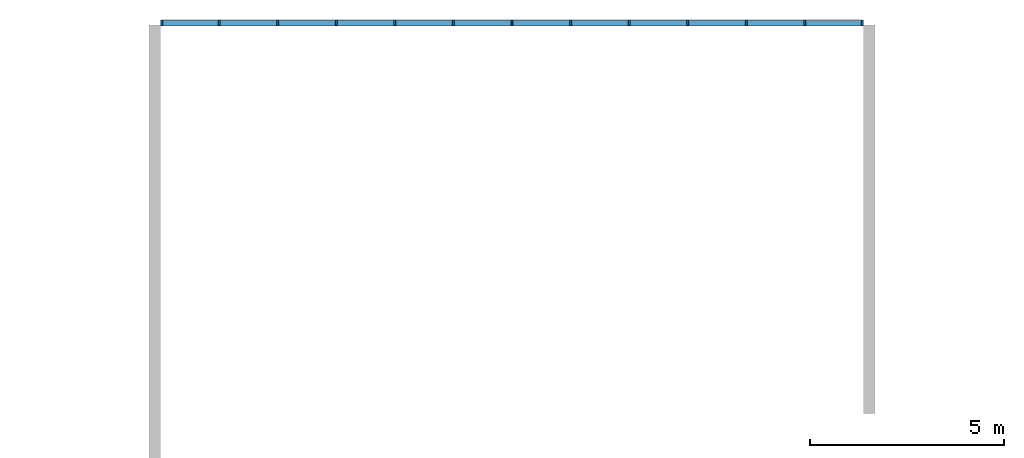
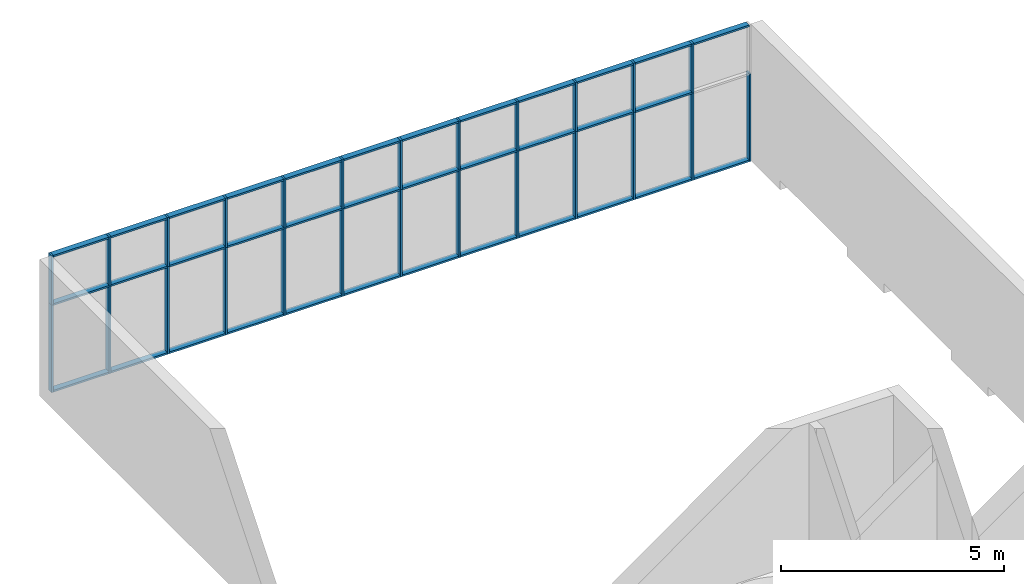
# One storey, part 4 of 13: 60 members, 1 element without a shape of its own.
"""IFC2X3 building model written with IfcOpenShell, lengths in millimetres."""

from ifc_helpers import new_model, entity, si_unit, converted_unit, derived_unit, direction, frame, frame_2d, origin, origin_2d_with_axis, place, context, subcontext, project, spatial, rectangle, extrude, material, type_object, element, aggregate, save


model = new_model("IFC2X3")

# Units and contexts
model_context = context("Model", 3, precision=0.01, world=origin(), true_north=direction((6.12303176911189e-17, 1.0)))
context_of_model = context(None, 3, precision=0.01, world=origin(), true_north=direction((6.12303176911189e-17, 1.0)))
body_context = subcontext(model_context, "Body", "Model", "MODEL_VIEW")
ifc_project = project(units=[si_unit("LENGTHUNIT", "METRE", prefix="MILLI"), si_unit("AREAUNIT", "SQUARE_METRE"), si_unit("VOLUMEUNIT", "CUBIC_METRE"), converted_unit("PLANEANGLEUNIT", "DEGREE", entity("IfcRatioMeasure", 0.0174532925199433), si_unit("PLANEANGLEUNIT", "RADIAN"), dimensions=[0, 0, 0, 0, 0, 0, 0]), si_unit("MASSUNIT", "GRAM", prefix="KILO"), si_unit("TIMEUNIT", "SECOND"), si_unit("FREQUENCYUNIT", "HERTZ"), si_unit("THERMODYNAMICTEMPERATUREUNIT", "DEGREE_CELSIUS"), derived_unit("THERMALTRANSMITTANCEUNIT", [(si_unit("MASSUNIT", "GRAM", prefix="KILO"), 1), (si_unit("THERMODYNAMICTEMPERATUREUNIT", "KELVIN"), -1), (si_unit("TIMEUNIT", "SECOND"), -3)]), derived_unit("VOLUMETRICFLOWRATEUNIT", [(si_unit("LENGTHUNIT", "METRE"), 3), (si_unit("TIMEUNIT", "SECOND"), -1)]), si_unit("ELECTRICCURRENTUNIT", "AMPERE"), si_unit("ELECTRICVOLTAGEUNIT", "VOLT"), si_unit("POWERUNIT", "WATT"), si_unit("FORCEUNIT", "NEWTON", prefix="KILO"), si_unit("ILLUMINANCEUNIT", "LUX"), si_unit("LUMINOUSFLUXUNIT", "LUMEN"), si_unit("LUMINOUSINTENSITYUNIT", "CANDELA"), si_unit("PRESSUREUNIT", "PASCAL")], contexts=[model_context, context_of_model])

# Site, building, storey
site_placement = place(None, origin())
site = spatial("IfcSite", under=ifc_project, at=site_placement, CompositionType="ELEMENT")
building_placement = place(site_placement, origin())
building = spatial("IfcBuilding", under=site, at=building_placement, CompositionType="ELEMENT")
storey_placement = place(building_placement, frame((0.0, 0.0, 3750.0)))
storey = spatial("IfcBuildingStorey", under=building, at=storey_placement, Name="02. 2 etg.", CompositionType="ELEMENT", Elevation=3750.00000000068)

# Curtain wall, members
curtain_wall_type = type_object("IfcCurtainWallType", Name="Curtain Wall:Storefront", PredefinedType="NOTDEFINED")
curtain_wall_placement = place(storey_placement, frame((0.0, 0.0, -3750.0)))
curtain_wall = element("IfcCurtainWall", 1, at=curtain_wall_placement, inside=storey, type_object=curtain_wall_type, Name="Curtain Wall:Storefront", ObjectType="Curtain Wall:Storefront")
ifc_material = material(Name="Aluminium")
member_1_placement = place(curtain_wall_placement, frame((28012.4511895081, 18905.0, 7450.0)))
member_1 = element("IfcMember", 2, at=member_1_placement, material=ifc_material, Name="Curtain Wall:Storefront:8486", ObjectType="Curtain Wall:Storefront:8486", context=body_context, shape_type="SweptSolid", body=[
    extrude(rectangle(XDim=1436.66666666667, YDim=150.000000000001, at=frame_2d((0.0, 1.08713038571295e-12), x_axis=(1.0, 0.0))), frame((718.333333333335, 75.0, 0.0), z_axis=(0.0, 0.0, 1.0), x_axis=(-1.0, 0.0, 0.0)), (0.0, 0.0, 1.0), 49.9999999999995),
])
member_2_placement = place(curtain_wall_placement, frame((11409.1178561748, 18905.0, 3750.0)))
member_2 = element("IfcMember", 3, at=member_2_placement, material=ifc_material, Name="Curtain Wall:Storefront:8486", ObjectType="Curtain Wall:Storefront:8486", context=body_context, shape_type="SweptSolid", body=[
    extrude(rectangle(XDim=1436.66666666667, YDim=150.000000000001, at=frame_2d((1.08002495835535e-12, 1.08713038571295e-12), x_axis=(1.0, 0.0))), frame((718.333333333335, 75.0, 0.0)), (0.0, 0.0, 1.0), 50.0),
])
member_3_placement = place(curtain_wall_placement, frame((29449.1178561748, 18905.0, 3750.0)))
member_3 = element("IfcMember", 4, at=member_3_placement, material=ifc_material, Name="Curtain Wall:Storefront:8486", ObjectType="Curtain Wall:Storefront:8486", context=body_context, shape_type="SweptSolid", body=[
    extrude(rectangle(XDim=149.999999999998, YDim=50.0000000000016, at=frame_2d((-1.08002495835535e-12, -2.16715534406831e-12), x_axis=(1.0, 0.0))), frame((25.0, 75.0, 0.0), z_axis=(0.0, 0.0, 1.0), x_axis=(0.0, 1.0, 0.0)), (0.0, 0.0, 1.0), 2400.0),
])
member_4_placement = place(curtain_wall_placement, frame((11359.1178561748, 18905.0, 6150.0)))
member_4 = element("IfcMember", 5, at=member_4_placement, material=ifc_material, Name="Curtain Wall:Storefront:8486", ObjectType="Curtain Wall:Storefront:8486", context=body_context, shape_type="SweptSolid", body=[
    extrude(rectangle(XDim=49.9999999999995, YDim=149.999999999998, at=frame_2d((2.16715534406831e-12, 1.08002495835535e-12), x_axis=(1.0, 0.0))), frame((25.0, 75.0, 0.0)), (0.0, 0.0, 1.0), 1349.99999999993),
])
member_5_placement = place(curtain_wall_placement, frame((11409.1178561748, 18905.0, 7450.0)))
member_5 = element("IfcMember", 6, at=member_5_placement, material=ifc_material, Name="Curtain Wall:Storefront:8486", ObjectType="Curtain Wall:Storefront:8486", context=body_context, shape_type="SweptSolid", body=[
    extrude(rectangle(XDim=1436.66666666667, YDim=150.000000000001, at=frame_2d((-1.08002495835535e-12, 1.08713038571295e-12), x_axis=(1.0, 0.0))), frame((718.333333333335, 75.0, 0.0), z_axis=(0.0, 0.0, 1.0), x_axis=(-1.0, 0.0, 0.0)), (0.0, 0.0, 1.0), 49.9999999999995),
])
member_6_placement = place(curtain_wall_placement, frame((12895.7845228414, 18905.0, 7450.0)))
member_6 = element("IfcMember", 7, at=member_6_placement, material=ifc_material, Name="Curtain Wall:Storefront:8486", ObjectType="Curtain Wall:Storefront:8486", context=body_context, shape_type="SweptSolid", body=[
    extrude(rectangle(XDim=1461.66666666667, YDim=150.000000000001, at=frame_2d((1.08002495835535e-12, 0.0), x_axis=(1.0, 0.0))), frame((730.833333333334, 75.0, 0.0), z_axis=(0.0, 0.0, 1.0), x_axis=(-1.0, 0.0, 0.0)), (0.0, 0.0, 1.0), 49.9999999999995),
])
member_7_placement = place(curtain_wall_placement, frame((14407.4511895081, 18905.0, 7450.0)))
member_7 = element("IfcMember", 8, at=member_7_placement, material=ifc_material, Name="Curtain Wall:Storefront:8486", ObjectType="Curtain Wall:Storefront:8486", context=body_context, shape_type="SweptSolid", body=[
    extrude(rectangle(XDim=1461.66666666667, YDim=150.000000000001, at=frame_2d((-1.08002495835535e-12, 0.0), x_axis=(1.0, 0.0))), frame((730.833333333332, 75.0, 0.0), z_axis=(0.0, 0.0, 1.0), x_axis=(-1.0, 0.0, 0.0)), (0.0, 0.0, 1.0), 49.9999999999995),
])
member_8_placement = place(curtain_wall_placement, frame((15919.1178561748, 18905.0, 7450.0)))
member_8 = element("IfcMember", 9, at=member_8_placement, material=ifc_material, Name="Curtain Wall:Storefront:8486", ObjectType="Curtain Wall:Storefront:8486", context=body_context, shape_type="SweptSolid", body=[
    extrude(rectangle(XDim=1461.66666666667, YDim=150.000000000001, at=frame_2d((-1.08002495835535e-12, 0.0), x_axis=(1.0, 0.0))), frame((730.833333333332, 75.0, 0.0), z_axis=(0.0, 0.0, 1.0), x_axis=(-1.0, 0.0, 0.0)), (0.0, 0.0, 1.0), 49.9999999999995),
])
member_9_placement = place(curtain_wall_placement, frame((17430.7845228414, 18905.0, 7450.0)))
member_9 = element("IfcMember", 10, at=member_9_placement, material=ifc_material, Name="Curtain Wall:Storefront:8486", ObjectType="Curtain Wall:Storefront:8486", context=body_context, shape_type="SweptSolid", body=[
    extrude(rectangle(XDim=1461.66666666666, YDim=150.000000000001, at=frame_2d((1.08002495835535e-12, 1.08713038571295e-12), x_axis=(1.0, 0.0))), frame((730.833333333332, 75.0, 0.0), z_axis=(0.0, 0.0, 1.0), x_axis=(-1.0, 0.0, 0.0)), (0.0, 0.0, 1.0), 49.9999999999995),
])
member_10_placement = place(curtain_wall_placement, frame((18942.4511895081, 18905.0, 7450.0)))
member_10 = element("IfcMember", 11, at=member_10_placement, material=ifc_material, Name="Curtain Wall:Storefront:8486", ObjectType="Curtain Wall:Storefront:8486", context=body_context, shape_type="SweptSolid", body=[
    extrude(rectangle(XDim=1461.66666666666, YDim=150.000000000001, at=frame_2d((1.08002495835535e-12, 0.0), x_axis=(1.0, 0.0))), frame((730.833333333332, 75.0, 0.0), z_axis=(0.0, 0.0, 1.0), x_axis=(-1.0, 0.0, 0.0)), (0.0, 0.0, 1.0), 49.9999999999995),
])
member_11_placement = place(curtain_wall_placement, frame((20454.1178561748, 18905.0, 7450.0)))
member_11 = element("IfcMember", 12, at=member_11_placement, material=ifc_material, Name="Curtain Wall:Storefront:8486", ObjectType="Curtain Wall:Storefront:8486", context=body_context, shape_type="SweptSolid", body=[
    extrude(rectangle(XDim=1461.66666666666, YDim=150.000000000001, at=frame_2d((0.0, 2.16715534406831e-12), x_axis=(1.0, 0.0))), frame((730.833333333332, 75.0, 0.0), z_axis=(0.0, 0.0, 1.0), x_axis=(-1.0, 0.0, 0.0)), (0.0, 0.0, 1.0), 49.9999999999995),
])
member_12_placement = place(curtain_wall_placement, frame((21965.7845228414, 18905.0, 7450.0)))
member_12 = element("IfcMember", 13, at=member_12_placement, material=ifc_material, Name="Curtain Wall:Storefront:8486", ObjectType="Curtain Wall:Storefront:8486", context=body_context, shape_type="SweptSolid", body=[
    extrude(rectangle(XDim=1461.66666666666, YDim=150.000000000001, at=frame_2d((0.0, 1.08713038571295e-12), x_axis=(1.0, 0.0))), frame((730.833333333332, 75.0, 0.0), z_axis=(0.0, 0.0, 1.0), x_axis=(-1.0, 0.0, 0.0)), (0.0, 0.0, 1.0), 49.9999999999995),
])
member_13_placement = place(curtain_wall_placement, frame((23477.4511895081, 18905.0, 7450.0)))
member_13 = element("IfcMember", 14, at=member_13_placement, material=ifc_material, Name="Curtain Wall:Storefront:8486", ObjectType="Curtain Wall:Storefront:8486", context=body_context, shape_type="SweptSolid", body=[
    extrude(rectangle(XDim=1461.66666666666, YDim=150.000000000001, at=origin_2d_with_axis()), frame((730.833333333332, 75.0, 0.0), z_axis=(0.0, 0.0, 1.0), x_axis=(-1.0, 0.0, 0.0)), (0.0, 0.0, 1.0), 49.9999999999995),
])
member_14_placement = place(curtain_wall_placement, frame((24989.1178561748, 18905.0, 7450.0)))
member_14 = element("IfcMember", 15, at=member_14_placement, material=ifc_material, Name="Curtain Wall:Storefront:8486", ObjectType="Curtain Wall:Storefront:8486", context=body_context, shape_type="SweptSolid", body=[
    extrude(rectangle(XDim=1461.66666666666, YDim=150.000000000001, at=origin_2d_with_axis()), frame((730.833333333332, 75.0, 0.0), z_axis=(0.0, 0.0, 1.0), x_axis=(-1.0, 0.0, 0.0)), (0.0, 0.0, 1.0), 49.9999999999995),
])
member_15_placement = place(curtain_wall_placement, frame((26500.7845228414, 18905.0, 7450.0)))
member_15 = element("IfcMember", 16, at=member_15_placement, material=ifc_material, Name="Curtain Wall:Storefront:8486", ObjectType="Curtain Wall:Storefront:8486", context=body_context, shape_type="SweptSolid", body=[
    extrude(rectangle(XDim=1461.66666666666, YDim=150.000000000001, at=origin_2d_with_axis()), frame((730.833333333332, 75.0, 0.0), z_axis=(0.0, 0.0, 1.0), x_axis=(-1.0, 0.0, 0.0)), (0.0, 0.0, 1.0), 49.9999999999995),
])
member_16_placement = place(curtain_wall_placement, frame((12895.7845228415, 18905.0, 3750.0)))
member_16 = element("IfcMember", 17, at=member_16_placement, material=ifc_material, Name="Curtain Wall:Storefront:8486", ObjectType="Curtain Wall:Storefront:8486", context=body_context, shape_type="SweptSolid", body=[
    extrude(rectangle(XDim=1461.66666666666, YDim=150.000000000001, at=frame_2d((1.08002495835535e-12, 0.0), x_axis=(1.0, 0.0))), frame((730.83333333333, 75.0, 0.0)), (0.0, 0.0, 1.0), 50.0),
])
member_17_placement = place(curtain_wall_placement, frame((14407.4511895081, 18905.0, 3750.0)))
member_17 = element("IfcMember", 18, at=member_17_placement, material=ifc_material, Name="Curtain Wall:Storefront:8486", ObjectType="Curtain Wall:Storefront:8486", context=body_context, shape_type="SweptSolid", body=[
    extrude(rectangle(XDim=1461.66666666666, YDim=150.000000000001, at=frame_2d((1.08002495835535e-12, 0.0), x_axis=(1.0, 0.0))), frame((730.83333333333, 75.0, 0.0)), (0.0, 0.0, 1.0), 50.0),
])
member_18_placement = place(curtain_wall_placement, frame((15919.1178561748, 18905.0, 3750.0)))
member_18 = element("IfcMember", 19, at=member_18_placement, material=ifc_material, Name="Curtain Wall:Storefront:8486", ObjectType="Curtain Wall:Storefront:8486", context=body_context, shape_type="SweptSolid", body=[
    extrude(rectangle(XDim=1461.66666666666, YDim=150.000000000001, at=frame_2d((-1.08002495835535e-12, 0.0), x_axis=(1.0, 0.0))), frame((730.833333333332, 75.0, 0.0)), (0.0, 0.0, 1.0), 50.0),
])
member_19_placement = place(curtain_wall_placement, frame((17430.7845228414, 18905.0, 3750.0)))
member_19 = element("IfcMember", 20, at=member_19_placement, material=ifc_material, Name="Curtain Wall:Storefront:8486", ObjectType="Curtain Wall:Storefront:8486", context=body_context, shape_type="SweptSolid", body=[
    extrude(rectangle(XDim=1461.66666666666, YDim=150.000000000001, at=frame_2d((1.08002495835535e-12, 1.08713038571295e-12), x_axis=(1.0, 0.0))), frame((730.83333333333, 75.0, 0.0)), (0.0, 0.0, 1.0), 50.0),
])
member_20_placement = place(curtain_wall_placement, frame((18942.4511895081, 18905.0, 3750.0)))
member_20 = element("IfcMember", 21, at=member_20_placement, material=ifc_material, Name="Curtain Wall:Storefront:8486", ObjectType="Curtain Wall:Storefront:8486", context=body_context, shape_type="SweptSolid", body=[
    extrude(rectangle(XDim=1461.66666666667, YDim=150.000000000001, at=frame_2d((-1.08002495835535e-12, 2.16715534406831e-12), x_axis=(1.0, 0.0))), frame((730.833333333332, 75.0, 0.0)), (0.0, 0.0, 1.0), 50.0),
])
member_21_placement = place(curtain_wall_placement, frame((20454.1178561748, 18905.0, 3750.0)))
member_21 = element("IfcMember", 22, at=member_21_placement, material=ifc_material, Name="Curtain Wall:Storefront:8486", ObjectType="Curtain Wall:Storefront:8486", context=body_context, shape_type="SweptSolid", body=[
    extrude(rectangle(XDim=1461.66666666666, YDim=150.000000000001, at=origin_2d_with_axis()), frame((730.833333333332, 75.0, 0.0)), (0.0, 0.0, 1.0), 50.0),
])
member_22_placement = place(curtain_wall_placement, frame((21965.7845228414, 18905.0, 3750.0)))
member_22 = element("IfcMember", 23, at=member_22_placement, material=ifc_material, Name="Curtain Wall:Storefront:8486", ObjectType="Curtain Wall:Storefront:8486", context=body_context, shape_type="SweptSolid", body=[
    extrude(rectangle(XDim=1461.66666666666, YDim=150.000000000001, at=frame_2d((0.0, 1.08713038571295e-12), x_axis=(1.0, 0.0))), frame((730.833333333332, 75.0, 0.0)), (0.0, 0.0, 1.0), 50.0),
])
member_23_placement = place(curtain_wall_placement, frame((23477.4511895081, 18905.0, 3750.0)))
member_23 = element("IfcMember", 24, at=member_23_placement, material=ifc_material, Name="Curtain Wall:Storefront:8486", ObjectType="Curtain Wall:Storefront:8486", context=body_context, shape_type="SweptSolid", body=[
    extrude(rectangle(XDim=1461.66666666666, YDim=150.000000000001, at=origin_2d_with_axis()), frame((730.833333333332, 75.0, 0.0)), (0.0, 0.0, 1.0), 50.0),
])
member_24_placement = place(curtain_wall_placement, frame((24989.1178561748, 18905.0, 3750.0)))
member_24 = element("IfcMember", 25, at=member_24_placement, material=ifc_material, Name="Curtain Wall:Storefront:8486", ObjectType="Curtain Wall:Storefront:8486", context=body_context, shape_type="SweptSolid", body=[
    extrude(rectangle(XDim=1461.66666666666, YDim=150.000000000001, at=origin_2d_with_axis()), frame((730.833333333332, 75.0, 0.0)), (0.0, 0.0, 1.0), 50.0),
])
member_25_placement = place(curtain_wall_placement, frame((26500.7845228414, 18905.0, 3750.0)))
member_25 = element("IfcMember", 26, at=member_25_placement, material=ifc_material, Name="Curtain Wall:Storefront:8486", ObjectType="Curtain Wall:Storefront:8486", context=body_context, shape_type="SweptSolid", body=[
    extrude(rectangle(XDim=1461.66666666666, YDim=150.000000000001, at=origin_2d_with_axis()), frame((730.833333333332, 75.0, 0.0)), (0.0, 0.0, 1.0), 50.0),
])
member_26_placement = place(curtain_wall_placement, frame((28012.4511895081, 18905.0, 3750.0)))
member_26 = element("IfcMember", 27, at=member_26_placement, material=ifc_material, Name="Curtain Wall:Storefront:8486", ObjectType="Curtain Wall:Storefront:8486", context=body_context, shape_type="SweptSolid", body=[
    extrude(rectangle(XDim=1436.66666666666, YDim=150.000000000001, at=frame_2d((-2.1600499167107e-12, 1.08713038571295e-12), x_axis=(1.0, 0.0))), frame((718.333333333339, 75.0, 0.0)), (0.0, 0.0, 1.0), 50.0),
])
member_27_placement = place(curtain_wall_placement, frame((11359.1178561748, 18905.0, 3750.0)))
member_27 = element("IfcMember", 28, at=member_27_placement, material=ifc_material, Name="Curtain Wall:Storefront:8486", ObjectType="Curtain Wall:Storefront:8486", context=body_context, shape_type="SweptSolid", body=[
    extrude(rectangle(XDim=50.0000000000016, YDim=150.000000000001, at=origin_2d_with_axis()), frame((25.0, 75.0, 0.0)), (0.0, 0.0, 1.0), 2400.0),
])
member_28_placement = place(curtain_wall_placement, frame((11409.1178561748, 18905.0, 6125.0)))
member_28 = element("IfcMember", 29, at=member_28_placement, material=ifc_material, Name="Curtain Wall:Storefront:8486", ObjectType="Curtain Wall:Storefront:8486", context=body_context, shape_type="SweptSolid", body=[
    extrude(rectangle(XDim=1436.66666666667, YDim=150.000000000001, at=frame_2d((1.08002495835535e-12, 1.08713038571295e-12), x_axis=(1.0, 0.0))), frame((718.333333333335, 75.0, 0.0), z_axis=(0.0, 0.0, 1.0), x_axis=(-1.0, 0.0, 0.0)), (0.0, 0.0, 1.0), 49.9999999999995),
])
member_29_placement = place(curtain_wall_placement, frame((12895.7845228414, 18905.0, 6125.0)))
member_29 = element("IfcMember", 30, at=member_29_placement, material=ifc_material, Name="Curtain Wall:Storefront:8486", ObjectType="Curtain Wall:Storefront:8486", context=body_context, shape_type="SweptSolid", body=[
    extrude(rectangle(XDim=1461.66666666667, YDim=149.999999999998, at=frame_2d((1.08002495835535e-12, -1.08002495835535e-12), x_axis=(1.0, 0.0))), frame((730.833333333334, 75.0, 0.0), z_axis=(0.0, 0.0, 1.0), x_axis=(-1.0, 0.0, 0.0)), (0.0, 0.0, 1.0), 49.9999999999995),
])
member_30_placement = place(curtain_wall_placement, frame((14407.4511895081, 18905.0, 6125.0)))
member_30 = element("IfcMember", 31, at=member_30_placement, material=ifc_material, Name="Curtain Wall:Storefront:8486", ObjectType="Curtain Wall:Storefront:8486", context=body_context, shape_type="SweptSolid", body=[
    extrude(rectangle(XDim=1461.66666666667, YDim=149.999999999998, at=frame_2d((-1.08002495835535e-12, 1.08002495835535e-12), x_axis=(1.0, 0.0))), frame((730.833333333332, 75.0, 0.0), z_axis=(0.0, 0.0, 1.0), x_axis=(-1.0, 0.0, 0.0)), (0.0, 0.0, 1.0), 49.9999999999995),
])
member_31_placement = place(curtain_wall_placement, frame((15919.1178561748, 18905.0, 6125.0)))
member_31 = element("IfcMember", 32, at=member_31_placement, material=ifc_material, Name="Curtain Wall:Storefront:8486", ObjectType="Curtain Wall:Storefront:8486", context=body_context, shape_type="SweptSolid", body=[
    extrude(rectangle(XDim=1461.66666666667, YDim=149.999999999998, at=frame_2d((-1.08002495835535e-12, -1.08002495835535e-12), x_axis=(1.0, 0.0))), frame((730.833333333332, 75.0, 0.0), z_axis=(0.0, 0.0, 1.0), x_axis=(-1.0, 0.0, 0.0)), (0.0, 0.0, 1.0), 49.9999999999995),
])
member_32_placement = place(curtain_wall_placement, frame((17430.7845228414, 18905.0, 6125.0)))
member_32 = element("IfcMember", 33, at=member_32_placement, material=ifc_material, Name="Curtain Wall:Storefront:8486", ObjectType="Curtain Wall:Storefront:8486", context=body_context, shape_type="SweptSolid", body=[
    extrude(rectangle(XDim=1461.66666666666, YDim=150.000000000001, at=frame_2d((1.08002495835535e-12, 1.08002495835535e-12), x_axis=(1.0, 0.0))), frame((730.833333333332, 75.0, 0.0), z_axis=(0.0, 0.0, 1.0), x_axis=(-1.0, 0.0, 0.0)), (0.0, 0.0, 1.0), 49.9999999999995),
])
member_33_placement = place(curtain_wall_placement, frame((18942.4511895081, 18905.0, 6125.0)))
member_33 = element("IfcMember", 34, at=member_33_placement, material=ifc_material, Name="Curtain Wall:Storefront:8486", ObjectType="Curtain Wall:Storefront:8486", context=body_context, shape_type="SweptSolid", body=[
    extrude(rectangle(XDim=1461.66666666666, YDim=150.000000000001, at=frame_2d((1.08002495835535e-12, 0.0), x_axis=(1.0, 0.0))), frame((730.833333333332, 75.0, 0.0), z_axis=(0.0, 0.0, 1.0), x_axis=(-1.0, 0.0, 0.0)), (0.0, 0.0, 1.0), 49.9999999999995),
])
member_34_placement = place(curtain_wall_placement, frame((20454.1178561748, 18905.0, 6125.0)))
member_34 = element("IfcMember", 35, at=member_34_placement, material=ifc_material, Name="Curtain Wall:Storefront:8486", ObjectType="Curtain Wall:Storefront:8486", context=body_context, shape_type="SweptSolid", body=[
    extrude(rectangle(XDim=1461.66666666666, YDim=150.000000000001, at=frame_2d((0.0, 2.16715534406831e-12), x_axis=(1.0, 0.0))), frame((730.833333333332, 75.0, 0.0), z_axis=(0.0, 0.0, 1.0), x_axis=(-1.0, 0.0, 0.0)), (0.0, 0.0, 1.0), 49.9999999999995),
])
member_35_placement = place(curtain_wall_placement, frame((21965.7845228414, 18905.0, 6125.0)))
member_35 = element("IfcMember", 36, at=member_35_placement, material=ifc_material, Name="Curtain Wall:Storefront:8486", ObjectType="Curtain Wall:Storefront:8486", context=body_context, shape_type="SweptSolid", body=[
    extrude(rectangle(XDim=1461.66666666666, YDim=149.999999999998, at=frame_2d((0.0, 2.16715534406831e-12), x_axis=(1.0, 0.0))), frame((730.833333333332, 75.0, 0.0), z_axis=(0.0, 0.0, 1.0), x_axis=(-1.0, 0.0, 0.0)), (0.0, 0.0, 1.0), 49.9999999999995),
])
member_36_placement = place(curtain_wall_placement, frame((23477.4511895081, 18905.0, 6125.0)))
member_36 = element("IfcMember", 37, at=member_36_placement, material=ifc_material, Name="Curtain Wall:Storefront:8486", ObjectType="Curtain Wall:Storefront:8486", context=body_context, shape_type="SweptSolid", body=[
    extrude(rectangle(XDim=1461.66666666666, YDim=149.999999999998, at=frame_2d((0.0, -1.08002495835535e-12), x_axis=(1.0, 0.0))), frame((730.833333333332, 75.0, 0.0), z_axis=(0.0, 0.0, 1.0), x_axis=(-1.0, 0.0, 0.0)), (0.0, 0.0, 1.0), 49.9999999999995),
])
member_37_placement = place(curtain_wall_placement, frame((24989.1178561748, 18905.0, 6125.0)))
member_37 = element("IfcMember", 38, at=member_37_placement, material=ifc_material, Name="Curtain Wall:Storefront:8486", ObjectType="Curtain Wall:Storefront:8486", context=body_context, shape_type="SweptSolid", body=[
    extrude(rectangle(XDim=1461.66666666666, YDim=149.999999999998, at=frame_2d((0.0, 1.08002495835535e-12), x_axis=(1.0, 0.0))), frame((730.833333333332, 75.0, 0.0), z_axis=(0.0, 0.0, 1.0), x_axis=(-1.0, 0.0, 0.0)), (0.0, 0.0, 1.0), 49.9999999999995),
])
member_38_placement = place(curtain_wall_placement, frame((26500.7845228414, 18905.0, 6125.0)))
member_38 = element("IfcMember", 39, at=member_38_placement, material=ifc_material, Name="Curtain Wall:Storefront:8486", ObjectType="Curtain Wall:Storefront:8486", context=body_context, shape_type="SweptSolid", body=[
    extrude(rectangle(XDim=1461.66666666666, YDim=149.999999999998, at=frame_2d((0.0, -1.08002495835535e-12), x_axis=(1.0, 0.0))), frame((730.833333333332, 75.0, 0.0), z_axis=(0.0, 0.0, 1.0), x_axis=(-1.0, 0.0, 0.0)), (0.0, 0.0, 1.0), 49.9999999999995),
])
member_39_placement = place(curtain_wall_placement, frame((12845.7845228414, 18905.0, 3750.0)))
member_39 = element("IfcMember", 40, at=member_39_placement, material=ifc_material, Name="Curtain Wall:Storefront:8486", ObjectType="Curtain Wall:Storefront:8486", context=body_context, shape_type="SweptSolid", body=[
    extrude(rectangle(XDim=149.999999999998, YDim=49.9999999999995, at=frame_2d((-1.08002495835535e-12, -1.08357767203415e-12), x_axis=(1.0, 0.0))), frame((25.0, 75.0, 0.0), z_axis=(0.0, 0.0, 1.0), x_axis=(0.0, 1.0, 0.0)), (0.0, 0.0, 1.0), 2400.0),
])
member_40_placement = place(curtain_wall_placement, frame((14357.4511895081, 18905.0, 3750.0)))
member_40 = element("IfcMember", 41, at=member_40_placement, material=ifc_material, Name="Curtain Wall:Storefront:8486", ObjectType="Curtain Wall:Storefront:8486", context=body_context, shape_type="SweptSolid", body=[
    extrude(rectangle(XDim=149.999999999998, YDim=49.9999999999995, at=frame_2d((1.08002495835535e-12, 1.08357767203415e-12), x_axis=(1.0, 0.0))), frame((25.0, 75.0, 0.0), z_axis=(0.0, 0.0, 1.0), x_axis=(0.0, 1.0, 0.0)), (0.0, 0.0, 1.0), 2400.0),
])
member_41_placement = place(curtain_wall_placement, frame((15869.1178561748, 18905.0, 3750.0)))
member_41 = element("IfcMember", 42, at=member_41_placement, material=ifc_material, Name="Curtain Wall:Storefront:8486", ObjectType="Curtain Wall:Storefront:8486", context=body_context, shape_type="SweptSolid", body=[
    extrude(rectangle(XDim=149.999999999998, YDim=49.9999999999995, at=frame_2d((1.08002495835535e-12, -1.08357767203415e-12), x_axis=(1.0, 0.0))), frame((25.0, 75.0, 0.0), z_axis=(0.0, 0.0, 1.0), x_axis=(0.0, 1.0, 0.0)), (0.0, 0.0, 1.0), 2400.0),
])
member_42_placement = place(curtain_wall_placement, frame((17380.7845228414, 18905.0, 3750.0)))
member_42 = element("IfcMember", 43, at=member_42_placement, material=ifc_material, Name="Curtain Wall:Storefront:8486", ObjectType="Curtain Wall:Storefront:8486", context=body_context, shape_type="SweptSolid", body=[
    extrude(rectangle(XDim=149.999999999998, YDim=49.9999999999995, at=frame_2d((1.08002495835535e-12, 1.08357767203415e-12), x_axis=(1.0, 0.0))), frame((25.0, 75.0, 0.0), z_axis=(0.0, 0.0, 1.0), x_axis=(0.0, 1.0, 0.0)), (0.0, 0.0, 1.0), 2400.0),
])
member_43_placement = place(curtain_wall_placement, frame((18892.4511895081, 18905.0, 3750.0)))
member_43 = element("IfcMember", 44, at=member_43_placement, material=ifc_material, Name="Curtain Wall:Storefront:8486", ObjectType="Curtain Wall:Storefront:8486", context=body_context, shape_type="SweptSolid", body=[
    extrude(rectangle(XDim=149.999999999998, YDim=49.9999999999995, at=frame_2d((-1.08002495835535e-12, -1.08357767203415e-12), x_axis=(1.0, 0.0))), frame((25.0, 75.0, 0.0), z_axis=(0.0, 0.0, 1.0), x_axis=(0.0, 1.0, 0.0)), (0.0, 0.0, 1.0), 2400.0),
])
member_44_placement = place(curtain_wall_placement, frame((20404.1178561748, 18905.0, 3750.0)))
member_44 = element("IfcMember", 45, at=member_44_placement, material=ifc_material, Name="Curtain Wall:Storefront:8486", ObjectType="Curtain Wall:Storefront:8486", context=body_context, shape_type="SweptSolid", body=[
    extrude(rectangle(XDim=149.999999999998, YDim=50.0000000000016, at=frame_2d((1.08002495835535e-12, -2.16715534406831e-12), x_axis=(1.0, 0.0))), frame((25.0, 75.0, 0.0), z_axis=(0.0, 0.0, 1.0), x_axis=(0.0, 1.0, 0.0)), (0.0, 0.0, 1.0), 2400.0),
])
member_45_placement = place(curtain_wall_placement, frame((21915.7845228414, 18905.0, 3750.0)))
member_45 = element("IfcMember", 46, at=member_45_placement, material=ifc_material, Name="Curtain Wall:Storefront:8486", ObjectType="Curtain Wall:Storefront:8486", context=body_context, shape_type="SweptSolid", body=[
    extrude(rectangle(XDim=149.999999999998, YDim=50.0000000000016, at=frame_2d((1.08002495835535e-12, 2.16715534406831e-12), x_axis=(1.0, 0.0))), frame((25.0, 75.0, 0.0), z_axis=(0.0, 0.0, 1.0), x_axis=(0.0, 1.0, 0.0)), (0.0, 0.0, 1.0), 2400.0),
])
member_46_placement = place(curtain_wall_placement, frame((23427.4511895081, 18905.0, 3750.0)))
member_46 = element("IfcMember", 47, at=member_46_placement, material=ifc_material, Name="Curtain Wall:Storefront:8486", ObjectType="Curtain Wall:Storefront:8486", context=body_context, shape_type="SweptSolid", body=[
    extrude(rectangle(XDim=149.999999999998, YDim=50.0000000000016, at=frame_2d((-1.08002495835535e-12, 2.16715534406831e-12), x_axis=(1.0, 0.0))), frame((25.0, 75.0, 0.0), z_axis=(0.0, 0.0, 1.0), x_axis=(0.0, 1.0, 0.0)), (0.0, 0.0, 1.0), 2400.0),
])
member_47_placement = place(curtain_wall_placement, frame((24939.1178561748, 18905.0, 3750.0)))
member_47 = element("IfcMember", 48, at=member_47_placement, material=ifc_material, Name="Curtain Wall:Storefront:8486", ObjectType="Curtain Wall:Storefront:8486", context=body_context, shape_type="SweptSolid", body=[
    extrude(rectangle(XDim=149.999999999998, YDim=50.0000000000016, at=frame_2d((1.08002495835535e-12, 2.16715534406831e-12), x_axis=(1.0, 0.0))), frame((25.0, 75.0, 0.0), z_axis=(0.0, 0.0, 1.0), x_axis=(0.0, 1.0, 0.0)), (0.0, 0.0, 1.0), 2400.0),
])
member_48_placement = place(curtain_wall_placement, frame((26450.7845228414, 18905.0, 3750.0)))
member_48 = element("IfcMember", 49, at=member_48_placement, material=ifc_material, Name="Curtain Wall:Storefront:8486", ObjectType="Curtain Wall:Storefront:8486", context=body_context, shape_type="SweptSolid", body=[
    extrude(rectangle(XDim=149.999999999998, YDim=50.0000000000016, at=frame_2d((1.08002495835535e-12, -2.16715534406831e-12), x_axis=(1.0, 0.0))), frame((25.0, 75.0, 0.0), z_axis=(0.0, 0.0, 1.0), x_axis=(0.0, 1.0, 0.0)), (0.0, 0.0, 1.0), 2400.0),
])
member_49_placement = place(curtain_wall_placement, frame((27962.4511895081, 18905.0, 3750.0)))
member_49 = element("IfcMember", 50, at=member_49_placement, material=ifc_material, Name="Curtain Wall:Storefront:8486", ObjectType="Curtain Wall:Storefront:8486", context=body_context, shape_type="SweptSolid", body=[
    extrude(rectangle(XDim=149.999999999998, YDim=50.0000000000016, at=frame_2d((1.08002495835535e-12, 2.16715534406831e-12), x_axis=(1.0, 0.0))), frame((25.0, 75.0, 0.0), z_axis=(0.0, 0.0, 1.0), x_axis=(0.0, 1.0, 0.0)), (0.0, 0.0, 1.0), 2400.0),
])
member_50_placement = place(curtain_wall_placement, frame((12845.7845228414, 18905.0, 6150.0)))
member_50 = element("IfcMember", 51, at=member_50_placement, material=ifc_material, Name="Curtain Wall:Storefront:8486", ObjectType="Curtain Wall:Storefront:8486", context=body_context, shape_type="SweptSolid", body=[
    extrude(rectangle(XDim=149.999999999998, YDim=49.9999999999995, at=frame_2d((-1.08002495835535e-12, -1.08357767203415e-12), x_axis=(1.0, 0.0))), frame((25.0, 75.0, 0.0), z_axis=(0.0, 0.0, 1.0), x_axis=(0.0, 1.0, 0.0)), (0.0, 0.0, 1.0), 1349.99999999993),
])
member_51_placement = place(curtain_wall_placement, frame((14357.4511895081, 18905.0, 6150.0)))
member_51 = element("IfcMember", 52, at=member_51_placement, material=ifc_material, Name="Curtain Wall:Storefront:8486", ObjectType="Curtain Wall:Storefront:8486", context=body_context, shape_type="SweptSolid", body=[
    extrude(rectangle(XDim=149.999999999998, YDim=49.9999999999995, at=frame_2d((1.08002495835535e-12, 1.08357767203415e-12), x_axis=(1.0, 0.0))), frame((25.0, 75.0, 0.0), z_axis=(0.0, 0.0, 1.0), x_axis=(0.0, 1.0, 0.0)), (0.0, 0.0, 1.0), 1349.99999999993),
])
member_52_placement = place(curtain_wall_placement, frame((15869.1178561748, 18905.0, 6150.0)))
member_52 = element("IfcMember", 53, at=member_52_placement, material=ifc_material, Name="Curtain Wall:Storefront:8486", ObjectType="Curtain Wall:Storefront:8486", context=body_context, shape_type="SweptSolid", body=[
    extrude(rectangle(XDim=149.999999999998, YDim=49.9999999999995, at=frame_2d((1.08002495835535e-12, -1.08357767203415e-12), x_axis=(1.0, 0.0))), frame((25.0, 75.0, 0.0), z_axis=(0.0, 0.0, 1.0), x_axis=(0.0, 1.0, 0.0)), (0.0, 0.0, 1.0), 1349.99999999993),
])
member_53_placement = place(curtain_wall_placement, frame((17380.7845228414, 18905.0, 6150.0)))
member_53 = element("IfcMember", 54, at=member_53_placement, material=ifc_material, Name="Curtain Wall:Storefront:8486", ObjectType="Curtain Wall:Storefront:8486", context=body_context, shape_type="SweptSolid", body=[
    extrude(rectangle(XDim=149.999999999998, YDim=49.9999999999995, at=frame_2d((1.08002495835535e-12, -1.08357767203415e-12), x_axis=(1.0, 0.0))), frame((25.0, 75.0, 0.0), z_axis=(0.0, 0.0, 1.0), x_axis=(0.0, 1.0, 0.0)), (0.0, 0.0, 1.0), 1349.99999999993),
])
member_54_placement = place(curtain_wall_placement, frame((18892.4511895081, 18905.0, 6150.0)))
member_54 = element("IfcMember", 55, at=member_54_placement, material=ifc_material, Name="Curtain Wall:Storefront:8486", ObjectType="Curtain Wall:Storefront:8486", context=body_context, shape_type="SweptSolid", body=[
    extrude(rectangle(XDim=149.999999999998, YDim=49.9999999999995, at=frame_2d((-1.08002495835535e-12, -1.08357767203415e-12), x_axis=(1.0, 0.0))), frame((25.0, 75.0, 0.0), z_axis=(0.0, 0.0, 1.0), x_axis=(0.0, 1.0, 0.0)), (0.0, 0.0, 1.0), 1349.99999999993),
])
member_55_placement = place(curtain_wall_placement, frame((20404.1178561748, 18905.0, 6150.0)))
member_55 = element("IfcMember", 56, at=member_55_placement, material=ifc_material, Name="Curtain Wall:Storefront:8486", ObjectType="Curtain Wall:Storefront:8486", context=body_context, shape_type="SweptSolid", body=[
    extrude(rectangle(XDim=149.999999999998, YDim=49.9999999999973, at=frame_2d((-1.08002495835535e-12, 0.0), x_axis=(1.0, 0.0))), frame((25.0, 75.0, 0.0), z_axis=(0.0, 0.0, 1.0), x_axis=(0.0, 1.0, 0.0)), (0.0, 0.0, 1.0), 1349.99999999993),
])
member_56_placement = place(curtain_wall_placement, frame((21915.7845228414, 18905.0, 6150.0)))
member_56 = element("IfcMember", 57, at=member_56_placement, material=ifc_material, Name="Curtain Wall:Storefront:8486", ObjectType="Curtain Wall:Storefront:8486", context=body_context, shape_type="SweptSolid", body=[
    extrude(rectangle(XDim=149.999999999998, YDim=49.9999999999973, at=frame_2d((-1.08002495835535e-12, 0.0), x_axis=(1.0, 0.0))), frame((25.0, 75.0, 0.0), z_axis=(0.0, 0.0, 1.0), x_axis=(0.0, 1.0, 0.0)), (0.0, 0.0, 1.0), 1349.99999999993),
])
member_57_placement = place(curtain_wall_placement, frame((23427.4511895081, 18905.0, 6150.0)))
member_57 = element("IfcMember", 58, at=member_57_placement, material=ifc_material, Name="Curtain Wall:Storefront:8486", ObjectType="Curtain Wall:Storefront:8486", context=body_context, shape_type="SweptSolid", body=[
    extrude(rectangle(XDim=149.999999999998, YDim=49.9999999999973, at=frame_2d((-1.08002495835535e-12, 0.0), x_axis=(1.0, 0.0))), frame((25.0, 75.0, 0.0), z_axis=(0.0, 0.0, 1.0), x_axis=(0.0, 1.0, 0.0)), (0.0, 0.0, 1.0), 1349.99999999993),
])
member_58_placement = place(curtain_wall_placement, frame((24939.1178561748, 18905.0, 6150.0)))
member_58 = element("IfcMember", 59, at=member_58_placement, material=ifc_material, Name="Curtain Wall:Storefront:8486", ObjectType="Curtain Wall:Storefront:8486", context=body_context, shape_type="SweptSolid", body=[
    extrude(rectangle(XDim=149.999999999998, YDim=49.9999999999973, at=frame_2d((1.08002495835535e-12, 0.0), x_axis=(1.0, 0.0))), frame((25.0, 75.0, 0.0), z_axis=(0.0, 0.0, 1.0), x_axis=(0.0, 1.0, 0.0)), (0.0, 0.0, 1.0), 1349.99999999993),
])
member_59_placement = place(curtain_wall_placement, frame((26450.7845228414, 18905.0, 6150.0)))
member_59 = element("IfcMember", 60, at=member_59_placement, material=ifc_material, Name="Curtain Wall:Storefront:8486", ObjectType="Curtain Wall:Storefront:8486", context=body_context, shape_type="SweptSolid", body=[
    extrude(rectangle(XDim=149.999999999998, YDim=49.9999999999973, at=frame_2d((1.08002495835535e-12, 0.0), x_axis=(1.0, 0.0))), frame((25.0, 75.0, 0.0), z_axis=(0.0, 0.0, 1.0), x_axis=(0.0, 1.0, 0.0)), (0.0, 0.0, 1.0), 1349.99999999993),
])
member_60_placement = place(curtain_wall_placement, frame((27962.4511895081, 18905.0, 6150.0)))
member_60 = element("IfcMember", 61, at=member_60_placement, material=ifc_material, Name="Curtain Wall:Storefront:8486", ObjectType="Curtain Wall:Storefront:8486", context=body_context, shape_type="SweptSolid", body=[
    extrude(rectangle(XDim=149.999999999998, YDim=49.9999999999973, at=frame_2d((1.08002495835535e-12, 0.0), x_axis=(1.0, 0.0))), frame((25.0, 75.0, 0.0), z_axis=(0.0, 0.0, 1.0), x_axis=(0.0, 1.0, 0.0)), (0.0, 0.0, 1.0), 1349.99999999993),
])
aggregate(curtain_wall, [member_1, member_2, member_3, member_4, member_5, member_6, member_7, member_8, member_9, member_10, member_11, member_12, member_13, member_14, member_15, member_16, member_17, member_18, member_19, member_20, member_21, member_22, member_23, member_24, member_25, member_26, member_27, member_28, member_29, member_30, member_31, member_32, member_33, member_34, member_35, member_36, member_37, member_38, member_39, member_40, member_41, member_42, member_43, member_44, member_45, member_46, member_47, member_48, member_49, member_50, member_51, member_52, member_53, member_54, member_55, member_56, member_57, member_58, member_59, member_60])

save(model, "model.ifc")
